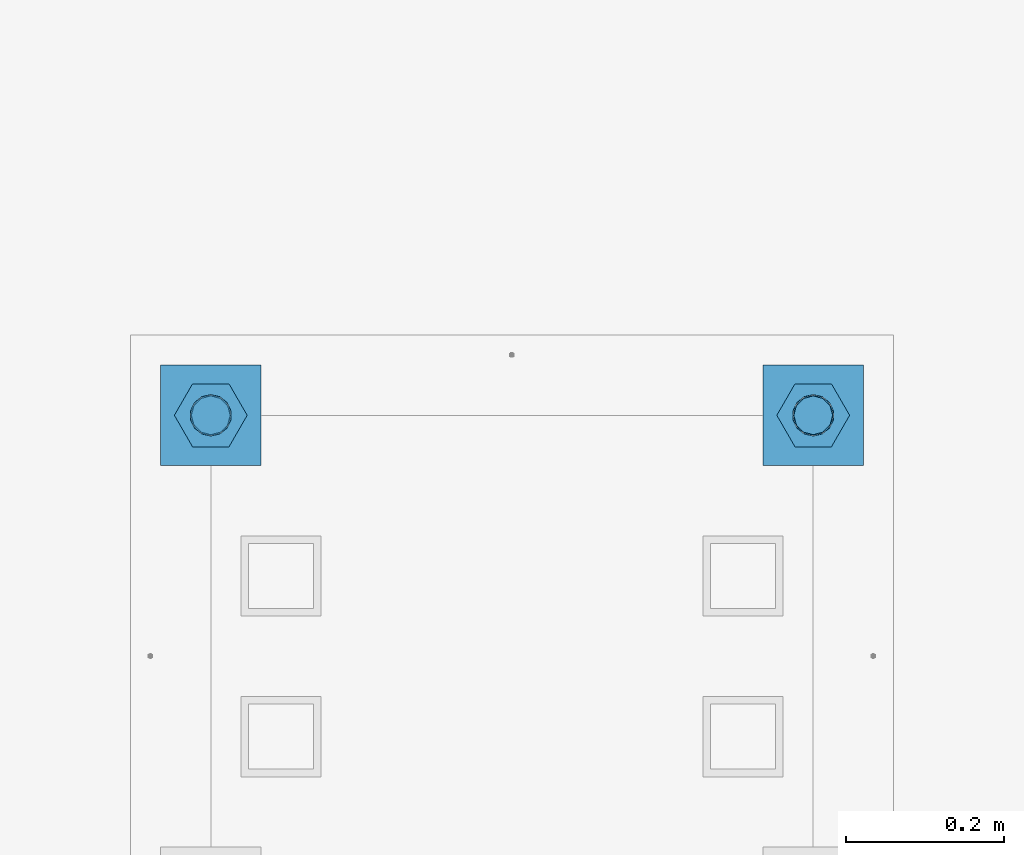
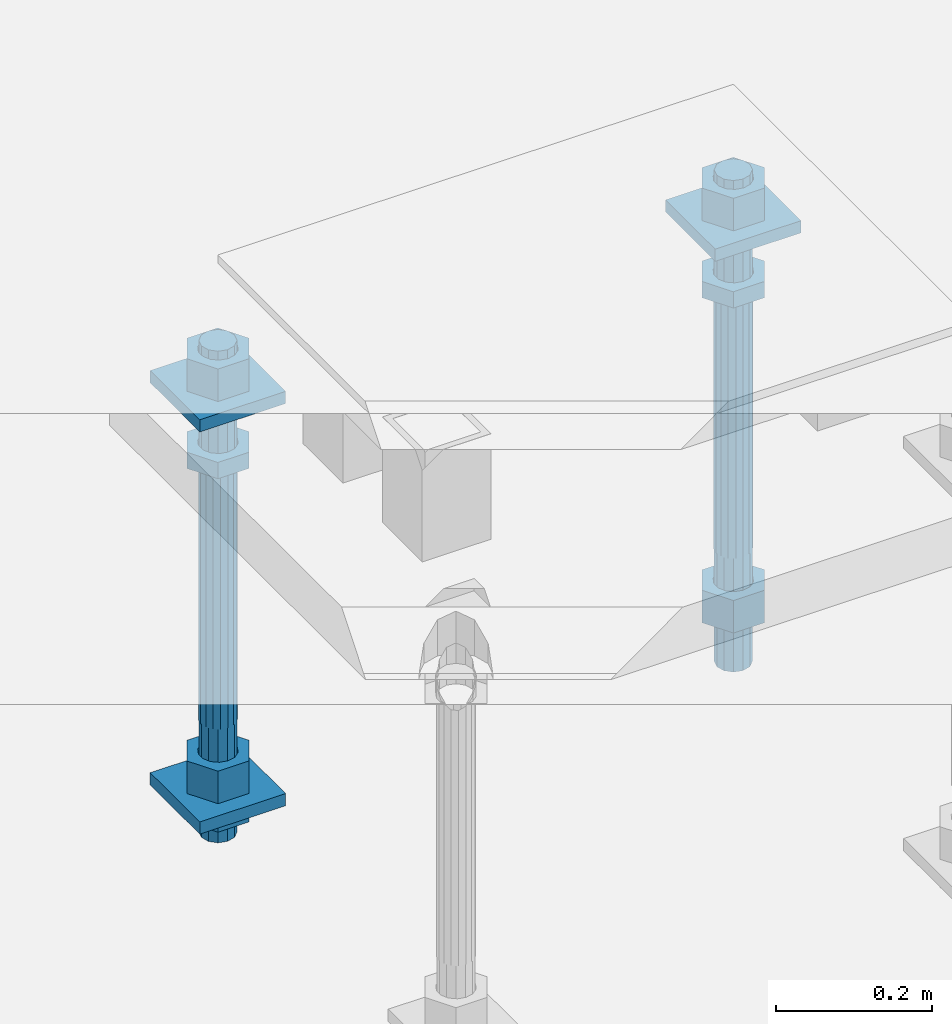
# One storey, part 2665 of 3843: 12 beams, 1 element without a shape of its own.
"""IFC2X3 building model written with IfcOpenShell, lengths in millimetres."""

import ifcopenshell
import ifcopenshell.guid

model = None  # the IFC model being written
_history = None  # IfcOwnerHistory: only IFC2X3 demands one
_inside = {}  # id of a spatial element -> (the spatial element, [elements in it])
_under = {}  # id of a project, library or spatial element -> (it, [spatial elements below it])
_declared = {}  # id of a project -> (the project, [libraries it declares])
_typed = {}  # id of a type object -> (the type object, [elements of that type])
_made_of = {}  # id of a material, layer set ... -> (it, [elements and type objects made of it])


def new_model(schema):
    """Start an empty IFC model of exactly this schema.

    Asked for "IFC4X3", IfcOpenShell would pick the latest addendum, in which some entities
    have other attributes; the version numbers below select the first issue.
    IFC2X3 requires an IfcOwnerHistory on every rooted entity: one is made here for all.
    """
    global model, _history
    if schema == "IFC4X3":
        model = ifcopenshell.file(schema_version=(4, 3, 0, 0))
    else:
        model = ifcopenshell.file(schema=schema)
    _inside.clear()
    _under.clear()
    _declared.clear()
    _typed.clear()
    _made_of.clear()
    _history = None
    if model.schema == "IFC2X3":
        org = make("IfcOrganization", Name="unknown")
        user = make(
            "IfcPersonAndOrganization",
            ThePerson=make("IfcPerson", FamilyName="unknown"),
            TheOrganization=org,
        )
        app = make(
            "IfcApplication",
            ApplicationDeveloper=org,
            Version="unknown",
            ApplicationFullName="unknown",
            ApplicationIdentifier="unknown",
        )
        _history = make(
            "IfcOwnerHistory",
            OwningUser=user,
            OwningApplication=app,
            ChangeAction="ADDED",
            CreationDate=0,
        )
    return model


def make(cls, **values):
    """One entity of the class cls with the attributes given. An attribute that is None is left unset."""
    return model.create_entity(
        cls, **{name: value for name, value in values.items() if value is not None}
    )


def rooted(cls, **values):
    """An entity with a GlobalId (a new one), such as an element, a storey or a relation."""
    return make(cls, GlobalId=ifcopenshell.guid.new(), OwnerHistory=_history, **values)


def si_unit(unit_type, name, prefix=None):
    """IfcSIUnit, for example si_unit("LENGTHUNIT", "METRE", prefix="MILLI")."""
    return make("IfcSIUnit", UnitType=unit_type, Prefix=prefix, Name=name)


def assignment(units):
    """IfcUnitAssignment: the units of a project."""
    return None if units is None else make("IfcUnitAssignment", Units=units)


def point(xyz):
    """IfcCartesianPoint."""
    return None if xyz is None else make("IfcCartesianPoint", Coordinates=xyz)


def direction(xyz):
    """IfcDirection."""
    return None if xyz is None else make("IfcDirection", DirectionRatios=xyz)


def frame(location, z_axis=None, x_axis=None):
    """IfcAxis2Placement3D, a coordinate frame: its origin and axes. An axis left out is left unset."""
    return make(
        "IfcAxis2Placement3D",
        Location=point(location),
        Axis=direction(z_axis),
        RefDirection=direction(x_axis),
    )


def origin_with_axes():
    """The frame at (0, 0, 0) with the z axis (0, 0, 1) and the x axis (1, 0, 0) written out."""
    return frame((0.0, 0.0, 0.0), z_axis=(0.0, 0.0, 1.0), x_axis=(1.0, 0.0, 0.0))


def place(relative_to, where):
    """IfcLocalPlacement: puts the frame where relative to a parent placement (None: the world)."""
    return make(
        "IfcLocalPlacement", PlacementRelTo=relative_to, RelativePlacement=where
    )


def context(
    kind, dimensions, precision=None, world=None, true_north=None, identifier=None
):
    """IfcGeometricRepresentationContext, for example the 3D "Model" context."""
    return make(
        "IfcGeometricRepresentationContext",
        ContextIdentifier=identifier,
        ContextType=kind,
        CoordinateSpaceDimension=dimensions,
        Precision=precision,
        WorldCoordinateSystem=world,
        TrueNorth=true_north,
    )


def subcontext(parent, identifier, kind, view, scale=None):
    """IfcGeometricRepresentationSubContext, for example "Body" below "Model"."""
    return make(
        "IfcGeometricRepresentationSubContext",
        ContextIdentifier=identifier,
        ContextType=kind,
        ParentContext=parent,
        TargetScale=scale,
        TargetView=view,
    )


def project(units=None, contexts=None):
    """IfcProject with its units and contexts."""
    return rooted(
        "IfcProject",
        Name="project",
        RepresentationContexts=contexts,
        UnitsInContext=assignment(units),
    )


def spatial(cls, under=None, at=None, **own):
    """A site, building, storey or space (cls), placed at a placement, below another one or the project."""
    s = rooted(cls, ObjectPlacement=at, **own)
    if under is not None:
        _under.setdefault(under.id(), (under, []))[1].append(s)
    return s


def faces_of(points, faces, orient=None, outer=None):
    """IfcFace entities. A face is a list of loops; a loop is a list of indices into points, from 0.

    orient and outer hold one flag for each loop. By default every Orientation is true, the
    first loop of a face is its IfcFaceOuterBound and the others are IfcFaceBound.
    """
    made = []
    for i, loops in enumerate(faces):
        bounds = []
        for j, loop in enumerate(loops):
            is_outer = j == 0 if outer is None else outer[i][j]
            bounds.append(
                make(
                    "IfcFaceOuterBound" if is_outer else "IfcFaceBound",
                    Bound=make("IfcPolyLoop", Polygon=[points[k] for k in loop]),
                    Orientation=True if orient is None else orient[i][j],
                )
            )
        made.append(make("IfcFace", Bounds=bounds))
    return made


def faceted_brep(points, faces, orient=None, outer=None, voids=None):
    """IfcFacetedBrep: a solid bounded by flat faces; with voids (closed shells), ...WithVoids."""
    shared = [point(p) for p in points]
    hull = make("IfcClosedShell", CfsFaces=faces_of(shared, faces, orient, outer))
    if voids is None:
        return make("IfcFacetedBrep", Outer=hull)
    return make(
        "IfcFacetedBrepWithVoids",
        Outer=hull,
        Voids=[
            make(cls, CfsFaces=faces_of(shared, fs, o, b)) for cls, fs, o, b in voids
        ],
    )


def shape(context_of_items, identifier, shape_type, items):
    """IfcShapeRepresentation: the items that make up one representation, for example the "Body"."""
    return make(
        "IfcShapeRepresentation",
        ContextOfItems=context_of_items,
        RepresentationIdentifier=identifier,
        RepresentationType=shape_type,
        Items=items,
    )


def material(Name=None, Category=None):
    """IfcMaterial."""
    return make("IfcMaterial", Name=Name, Category=Category)


def made_of(thing, what):
    """Note that an element or type object is made of a material, layer set ...; save() writes the relation."""
    if what is not None:
        _made_of.setdefault(what.id(), (what, []))[1].append(thing)
    return thing


def type_object(cls, material=None, **own):
    """A type object (cls), such as IfcWallType, which elements share."""
    return made_of(rooted(cls, **own), material)


def element(
    cls,
    number,
    at=None,
    inside=None,
    cuts=None,
    type_object=None,
    material=None,
    context=None,
    identifier="Body",
    shape_type=None,
    held_by="IfcProductDefinitionShape",
    body=None,
    shapes=None,
    **own,
):
    """One element of the class cls, such as IfcWall. Its Tag is "e" and its number.

    at: its placement. inside: the storey or other place that contains it. cuts: it is an
    opening in that element (IfcRelVoidsElement). A single representation is given by context,
    identifier, shape_type and body (its items); several are given by shapes. held_by: the class
    of the entity that holds the representations. save() writes the other relations.
    """
    e = rooted(cls, Tag="e%d" % number, ObjectPlacement=at, **own)
    if body is not None:
        shapes = [shape(context, identifier, shape_type, body)]
    if shapes is not None:
        e.Representation = make(held_by, Representations=shapes)
    if inside is not None:
        _inside.setdefault(inside.id(), (inside, []))[1].append(e)
    if cuts is not None:
        rooted(
            "IfcRelVoidsElement", RelatingBuildingElement=cuts, RelatedOpeningElement=e
        )
    if type_object is not None:
        _typed.setdefault(type_object.id(), (type_object, []))[1].append(e)
    return made_of(e, material)


def aggregate(whole, parts):
    """IfcRelAggregates: a whole, such as a stair, and the parts it consists of."""
    return rooted("IfcRelAggregates", RelatingObject=whole, RelatedObjects=parts)


def save(model, path):
    """Write the relations noted so far, then the file.

    IfcRelAggregates (storeys below a building ...), IfcRelContainedInSpatialStructure (elements
    in a storey), IfcRelDefinesByType, IfcRelAssociatesMaterial and IfcRelDeclares: one each for
    every whole, place, type object, material and project.
    """
    for whole, parts in _under.values():
        aggregate(whole, parts)
    for where, things in _inside.values():
        rooted(
            "IfcRelContainedInSpatialStructure",
            RelatedElements=things,
            RelatingStructure=where,
        )
    for kind, things in _typed.values():
        rooted("IfcRelDefinesByType", RelatedObjects=things, RelatingType=kind)
    for what, things in _made_of.values():
        rooted("IfcRelAssociatesMaterial", RelatedObjects=things, RelatingMaterial=what)
    for by, libraries in _declared.values():
        rooted("IfcRelDeclares", RelatingContext=by, RelatedDefinitions=libraries)
    model.write(path)


model = new_model("IFC2X3")

# Units and contexts
model_context = context("Model", 3, precision=1e-05, world=origin_with_axes())
body_context = subcontext(model_context, "Body", "Model", "MODEL_VIEW")
ifc_project = project(units=[si_unit("LENGTHUNIT", "METRE", prefix="MILLI"), si_unit("AREAUNIT", "SQUARE_METRE"), si_unit("VOLUMEUNIT", "CUBIC_METRE"), si_unit("MASSUNIT", "GRAM", prefix="KILO"), si_unit("TIMEUNIT", "SECOND"), si_unit("PLANEANGLEUNIT", "RADIAN"), si_unit("SOLIDANGLEUNIT", "STERADIAN"), si_unit("THERMODYNAMICTEMPERATUREUNIT", "DEGREE_CELSIUS"), si_unit("LUMINOUSINTENSITYUNIT", "LUMEN")], contexts=[model_context])

# Site, building, storey
site_placement = place(None, origin_with_axes())
site = spatial("IfcSite", under=ifc_project, at=site_placement, CompositionType="ELEMENT")
building_placement = place(site_placement, origin_with_axes())
building = spatial("IfcBuilding", under=site, at=building_placement, Name="Undefined", CompositionType="ELEMENT")
storey_placement = place(building_placement, origin_with_axes())
storey = spatial("IfcBuildingStorey", under=building, at=storey_placement, Name="Undefined", CompositionType="ELEMENT", Elevation=0.0)

# Assembly, beams
assembly_placement = place(storey_placement, origin_with_axes())
assembly = element("IfcElementAssembly", 1, at=assembly_placement, inside=storey, Name="TEMPLATE", AssemblyPlace="NOTDEFINED", PredefinedType="RIGID_FRAME")
ifc_material_1 = material(Name="STEEL/A572-50")
beam_type_1 = type_object("IfcBeamType", PredefinedType="NOTDEFINED")
beam_1_placement = place(assembly_placement, frame((118465.6, 18059.4000015259, 29873.575), z_axis=(1.0, 0.0, 0.0), x_axis=(0.0, 1.0, 0.0)))
beam_1 = element("IfcBeam", 2, at=beam_1_placement, type_object=beam_type_1, material=ifc_material_1, Name="WASHER_PLATE", context=body_context, shape_type="Brep", body=[
    faceted_brep([(0.0, 9.52500000000146, -63.5), (0.0, 9.52500000000146, 63.5), (127.0, 9.52500000000146, 63.5), (127.0, 9.52500000000146, -63.5), (0.0, -9.52500000000146, 63.5), (127.0, -9.52500000000146, 63.5), (0.0, -9.52500000000146, -63.5), (127.0, -9.52500000000146, -63.5)], [[[0, 1, 2, 3]], [[1, 4, 5, 2]], [[4, 6, 7, 5]], [[6, 0, 3, 7]], [[5, 7, 3, 2]], [[6, 4, 1, 0]]]),
])
beam_2_placement = place(assembly_placement, frame((119227.6, 18059.4000015259, 29873.575), z_axis=(1.0, 0.0, 0.0), x_axis=(0.0, 1.0, 0.0)))
beam_2 = element("IfcBeam", 3, at=beam_2_placement, type_object=beam_type_1, material=ifc_material_1, Name="WASHER_PLATE", context=body_context, shape_type="Brep", body=[
    faceted_brep([(0.0, 9.52500000000146, -63.5), (0.0, 9.52500000000146, 63.5), (127.0, 9.52500000000146, 63.5), (127.0, 9.52500000000146, -63.5), (0.0, -9.52500000000146, 63.5), (127.0, -9.52500000000146, 63.5), (0.0, -9.52500000000146, -63.5), (127.0, -9.52500000000146, -63.5)], [[[0, 1, 2, 3]], [[1, 4, 5, 2]], [[4, 6, 7, 5]], [[6, 0, 3, 7]], [[5, 7, 3, 2]], [[6, 4, 1, 0]]]),
])
beam_3_placement = place(assembly_placement, frame((118465.6, 18059.4000015259, 29244.925), z_axis=(1.0, 0.0, 0.0), x_axis=(0.0, 1.0, 0.0)))
beam_3 = element("IfcBeam", 4, at=beam_3_placement, type_object=beam_type_1, material=ifc_material_1, Name="WASHER_PLATE", context=body_context, shape_type="Brep", body=[
    faceted_brep([(0.0, 9.52500000000146, -63.5), (0.0, 9.52500000000146, 63.5), (127.0, 9.52500000000146, 63.5), (127.0, 9.52500000000146, -63.5), (0.0, -9.52500000000146, 63.5), (127.0, -9.52500000000146, 63.5), (0.0, -9.52500000000146, -63.5), (127.0, -9.52500000000146, -63.5)], [[[0, 1, 2, 3]], [[1, 4, 5, 2]], [[4, 6, 7, 5]], [[6, 0, 3, 7]], [[5, 7, 3, 2]], [[6, 4, 1, 0]]]),
])
ifc_material_2 = material(Name="STEEL/A36")
beam_type_2 = type_object("IfcBeamType", Name="2_HALF_NUT", PredefinedType="NOTDEFINED")
beam_4_placement = place(assembly_placement, frame((118465.6, 18122.9000015259, 29787.85), z_axis=(0.0, 1.0, 0.0), x_axis=(0.0, 0.0, -1.0)))
beam_4 = element("IfcBeam", 5, at=beam_4_placement, type_object=beam_type_2, material=ifc_material_2, Name="NUT", ObjectType="2_HALF_NUT", context=body_context, shape_type="Brep", body=[
    faceted_brep([(0.0, -46.0369987487793, 0.0), (0.0, -23.0184993743896, -39.869213104248), (25.4000000000015, -23.0184993743896, -39.869213104248), (25.4000000000015, -46.0369987487793, 0.0), (0.0, 23.0184993743896, -39.869213104248), (25.4000000000015, 23.0184993743896, -39.869213104248), (0.0, 46.0369987487793, 0.0), (25.4000000000015, 46.0369987487793, 0.0), (0.0, 23.0184993743896, 39.869213104248), (25.4000000000015, 23.0184993743896, 39.869213104248), (0.0, -23.0184993743896, 39.869213104248), (25.4000000000015, -23.0184993743896, 39.869213104248), (0.0, 0.0, 26.1940002441406), (0.0, 11.3650617044477, 23.5999013092805), (25.4000000000015, 11.3650617044477, 23.5999013092805), (25.4000000000015, 0.0, 26.1940002441406), (0.0, 20.4791109456419, 16.3316083006721), (25.4000000000015, 20.4791109456419, 16.3316083006721), (0.0, 25.5370200498292, 5.82867859874386), (25.4000000000015, 25.5370200498292, 5.82867859874386), (0.0, 25.5370200498292, -5.82867859874386), (25.4000000000015, 25.5370200498292, -5.82867859874386), (0.0, 20.4791109456419, -16.3316083006721), (25.4000000000015, 20.4791109456419, -16.3316083006721), (0.0, 11.3650617044477, -23.5999013092805), (25.4000000000015, 11.3650617044477, -23.5999013092805), (0.0, 0.0, -26.1940002441406), (25.4000000000015, 0.0, -26.1940002441406), (0.0, -11.3650617044477, -23.5999013092805), (25.4000000000015, -11.3650617044477, -23.5999013092805), (0.0, -20.4791109456419, -16.3316083006721), (25.4000000000015, -20.4791109456419, -16.3316083006721), (0.0, -25.5370200498292, -5.82867859874386), (25.4000000000015, -25.5370200498292, -5.82867859874386), (0.0, -25.5370200498292, 5.82867859874386), (25.4000000000015, -25.5370200498292, 5.82867859874386), (0.0, -20.4791109456419, 16.3316083006721), (25.4000000000015, -20.4791109456419, 16.3316083006721), (0.0, -11.3650617044477, 23.5999013092805), (25.4000000000015, -11.3650617044477, 23.5999013092805)], [[[0, 1, 2, 3]], [[1, 4, 5, 2]], [[4, 6, 7, 5]], [[6, 8, 9, 7]], [[8, 10, 11, 9]], [[10, 0, 3, 11]], [[12, 13, 14, 15]], [[13, 16, 17, 14]], [[16, 18, 19, 17]], [[18, 20, 21, 19]], [[20, 22, 23, 21]], [[22, 24, 25, 23]], [[24, 26, 27, 25]], [[26, 28, 29, 27]], [[28, 30, 31, 29]], [[30, 32, 33, 31]], [[32, 34, 35, 33]], [[34, 36, 37, 35]], [[36, 38, 39, 37]], [[38, 12, 15, 39]], [[5, 7, 9, 11, 3, 2], [17, 19, 21, 23, 25, 27, 29, 31, 33, 35, 37, 39, 15, 14]], [[10, 8, 6, 4, 1, 0], [38, 36, 34, 32, 30, 28, 26, 24, 22, 20, 18, 16, 13, 12]]]),
])
beam_5_placement = place(assembly_placement, frame((118465.6, 18122.9000015259, 29235.4), z_axis=(0.0, 1.0, 0.0), x_axis=(0.0, 0.0, -1.0)))
beam_5 = element("IfcBeam", 6, at=beam_5_placement, type_object=beam_type_2, material=ifc_material_2, Name="NUT", ObjectType="2_HALF_NUT", context=body_context, shape_type="Brep", body=[
    faceted_brep([(0.0, -46.0369987487793, 0.0), (0.0, -23.0184993743896, -39.869213104248), (25.4000000000015, -23.0184993743896, -39.869213104248), (25.4000000000015, -46.0369987487793, 0.0), (0.0, 23.0184993743896, -39.869213104248), (25.4000000000015, 23.0184993743896, -39.869213104248), (0.0, 46.0369987487793, 0.0), (25.4000000000015, 46.0369987487793, 0.0), (0.0, 23.0184993743896, 39.869213104248), (25.4000000000015, 23.0184993743896, 39.869213104248), (0.0, -23.0184993743896, 39.869213104248), (25.4000000000015, -23.0184993743896, 39.869213104248), (0.0, 0.0, 26.1940002441406), (0.0, 11.3650617044477, 23.5999013092805), (25.4000000000015, 11.3650617044477, 23.5999013092805), (25.4000000000015, 0.0, 26.1940002441406), (0.0, 20.4791109456419, 16.3316083006721), (25.4000000000015, 20.4791109456419, 16.3316083006721), (0.0, 25.5370200498292, 5.82867859874386), (25.4000000000015, 25.5370200498292, 5.82867859874386), (0.0, 25.5370200498292, -5.82867859874386), (25.4000000000015, 25.5370200498292, -5.82867859874386), (0.0, 20.4791109456419, -16.3316083006721), (25.4000000000015, 20.4791109456419, -16.3316083006721), (0.0, 11.3650617044477, -23.5999013092805), (25.4000000000015, 11.3650617044477, -23.5999013092805), (0.0, 0.0, -26.1940002441406), (25.4000000000015, 0.0, -26.1940002441406), (0.0, -11.3650617044477, -23.5999013092805), (25.4000000000015, -11.3650617044477, -23.5999013092805), (0.0, -20.4791109456419, -16.3316083006721), (25.4000000000015, -20.4791109456419, -16.3316083006721), (0.0, -25.5370200498292, -5.82867859874386), (25.4000000000015, -25.5370200498292, -5.82867859874386), (0.0, -25.5370200498292, 5.82867859874386), (25.4000000000015, -25.5370200498292, 5.82867859874386), (0.0, -20.4791109456419, 16.3316083006721), (25.4000000000015, -20.4791109456419, 16.3316083006721), (0.0, -11.3650617044477, 23.5999013092805), (25.4000000000015, -11.3650617044477, 23.5999013092805)], [[[0, 1, 2, 3]], [[1, 4, 5, 2]], [[4, 6, 7, 5]], [[6, 8, 9, 7]], [[8, 10, 11, 9]], [[10, 0, 3, 11]], [[12, 13, 14, 15]], [[13, 16, 17, 14]], [[16, 18, 19, 17]], [[18, 20, 21, 19]], [[20, 22, 23, 21]], [[22, 24, 25, 23]], [[24, 26, 27, 25]], [[26, 28, 29, 27]], [[28, 30, 31, 29]], [[30, 32, 33, 31]], [[32, 34, 35, 33]], [[34, 36, 37, 35]], [[36, 38, 39, 37]], [[38, 12, 15, 39]], [[5, 7, 9, 11, 3, 2], [17, 19, 21, 23, 25, 27, 29, 31, 33, 35, 37, 39, 15, 14]], [[10, 8, 6, 4, 1, 0], [38, 36, 34, 32, 30, 28, 26, 24, 22, 20, 18, 16, 13, 12]]]),
])
beam_6_placement = place(assembly_placement, frame((119227.6, 18122.9000015259, 29787.85), z_axis=(0.0, 1.0, 0.0), x_axis=(0.0, 0.0, -1.0)))
beam_6 = element("IfcBeam", 7, at=beam_6_placement, type_object=beam_type_2, material=ifc_material_2, Name="NUT", ObjectType="2_HALF_NUT", context=body_context, shape_type="Brep", body=[
    faceted_brep([(0.0, -46.0369987487793, 0.0), (0.0, -23.0184993743896, -39.869213104248), (25.4000000000015, -23.0184993743896, -39.869213104248), (25.4000000000015, -46.0369987487793, 0.0), (0.0, 23.0184993743896, -39.869213104248), (25.4000000000015, 23.0184993743896, -39.869213104248), (0.0, 46.0369987487793, 0.0), (25.4000000000015, 46.0369987487793, 0.0), (0.0, 23.0184993743896, 39.869213104248), (25.4000000000015, 23.0184993743896, 39.869213104248), (0.0, -23.0184993743896, 39.869213104248), (25.4000000000015, -23.0184993743896, 39.869213104248), (0.0, 0.0, 26.1940002441406), (0.0, 11.3650617044477, 23.5999013092805), (25.4000000000015, 11.3650617044477, 23.5999013092805), (25.4000000000015, 0.0, 26.1940002441406), (0.0, 20.4791109456419, 16.3316083006721), (25.4000000000015, 20.4791109456419, 16.3316083006721), (0.0, 25.5370200498292, 5.82867859874386), (25.4000000000015, 25.5370200498292, 5.82867859874386), (0.0, 25.5370200498292, -5.82867859874386), (25.4000000000015, 25.5370200498292, -5.82867859874386), (0.0, 20.4791109456419, -16.3316083006721), (25.4000000000015, 20.4791109456419, -16.3316083006721), (0.0, 11.3650617044477, -23.5999013092805), (25.4000000000015, 11.3650617044477, -23.5999013092805), (0.0, 0.0, -26.1940002441406), (25.4000000000015, 0.0, -26.1940002441406), (0.0, -11.3650617044477, -23.5999013092805), (25.4000000000015, -11.3650617044477, -23.5999013092805), (0.0, -20.4791109456419, -16.3316083006721), (25.4000000000015, -20.4791109456419, -16.3316083006721), (0.0, -25.5370200498292, -5.82867859874386), (25.4000000000015, -25.5370200498292, -5.82867859874386), (0.0, -25.5370200498292, 5.82867859874386), (25.4000000000015, -25.5370200498292, 5.82867859874386), (0.0, -20.4791109456419, 16.3316083006721), (25.4000000000015, -20.4791109456419, 16.3316083006721), (0.0, -11.3650617044477, 23.5999013092805), (25.4000000000015, -11.3650617044477, 23.5999013092805)], [[[0, 1, 2, 3]], [[1, 4, 5, 2]], [[4, 6, 7, 5]], [[6, 8, 9, 7]], [[8, 10, 11, 9]], [[10, 0, 3, 11]], [[12, 13, 14, 15]], [[13, 16, 17, 14]], [[16, 18, 19, 17]], [[18, 20, 21, 19]], [[20, 22, 23, 21]], [[22, 24, 25, 23]], [[24, 26, 27, 25]], [[26, 28, 29, 27]], [[28, 30, 31, 29]], [[30, 32, 33, 31]], [[32, 34, 35, 33]], [[34, 36, 37, 35]], [[36, 38, 39, 37]], [[38, 12, 15, 39]], [[5, 7, 9, 11, 3, 2], [17, 19, 21, 23, 25, 27, 29, 31, 33, 35, 37, 39, 15, 14]], [[10, 8, 6, 4, 1, 0], [38, 36, 34, 32, 30, 28, 26, 24, 22, 20, 18, 16, 13, 12]]]),
])
beam_type_3 = type_object("IfcBeamType", Name="2_HEAVY_HEX_NUT", PredefinedType="NOTDEFINED")
beam_7_placement = place(assembly_placement, frame((118465.6, 18122.9000015259, 29933.9), z_axis=(0.0, 1.0, 0.0), x_axis=(0.0, 0.0, -1.0)))
beam_7 = element("IfcBeam", 8, at=beam_7_placement, type_object=beam_type_3, material=ifc_material_2, Name="NUT", ObjectType="2_HEAVY_HEX_NUT", context=body_context, shape_type="Brep", body=[
    faceted_brep([(0.0, -46.0369987487793, 0.0), (0.0, -23.0184993743896, -39.869213104248), (50.7999999999993, -23.0184993743896, -39.869213104248), (50.7999999999993, -46.0369987487793, 0.0), (0.0, 23.0184993743896, -39.869213104248), (50.7999999999993, 23.0184993743896, -39.869213104248), (0.0, 46.0369987487793, 0.0), (50.7999999999993, 46.0369987487793, 0.0), (0.0, 23.0184993743896, 39.869213104248), (50.7999999999993, 23.0184993743896, 39.869213104248), (0.0, -23.0184993743896, 39.869213104248), (50.7999999999993, -23.0184993743896, 39.869213104248), (0.0, 0.0, 26.1940002441406), (0.0, 11.3650617044477, 23.5999013092805), (50.7999999999993, 11.3650617044477, 23.5999013092805), (50.7999999999993, 0.0, 26.1940002441406), (0.0, 20.4791109456419, 16.3316083006721), (50.7999999999993, 20.4791109456419, 16.3316083006721), (0.0, 25.5370200498292, 5.82867859874386), (50.7999999999993, 25.5370200498292, 5.82867859874386), (0.0, 25.5370200498292, -5.82867859874386), (50.7999999999993, 25.5370200498292, -5.82867859874386), (0.0, 20.4791109456419, -16.3316083006721), (50.7999999999993, 20.4791109456419, -16.3316083006721), (0.0, 11.3650617044477, -23.5999013092805), (50.7999999999993, 11.3650617044477, -23.5999013092805), (0.0, 0.0, -26.1940002441406), (50.7999999999993, 0.0, -26.1940002441406), (0.0, -11.3650617044477, -23.5999013092805), (50.7999999999993, -11.3650617044477, -23.5999013092805), (0.0, -20.4791109456419, -16.3316083006721), (50.7999999999993, -20.4791109456419, -16.3316083006721), (0.0, -25.5370200498292, -5.82867859874386), (50.7999999999993, -25.5370200498292, -5.82867859874386), (0.0, -25.5370200498292, 5.82867859874386), (50.7999999999993, -25.5370200498292, 5.82867859874386), (0.0, -20.4791109456419, 16.3316083006721), (50.7999999999993, -20.4791109456419, 16.3316083006721), (0.0, -11.3650617044477, 23.5999013092805), (50.7999999999993, -11.3650617044477, 23.5999013092805)], [[[0, 1, 2, 3]], [[1, 4, 5, 2]], [[4, 6, 7, 5]], [[6, 8, 9, 7]], [[8, 10, 11, 9]], [[10, 0, 3, 11]], [[12, 13, 14, 15]], [[13, 16, 17, 14]], [[16, 18, 19, 17]], [[18, 20, 21, 19]], [[20, 22, 23, 21]], [[22, 24, 25, 23]], [[24, 26, 27, 25]], [[26, 28, 29, 27]], [[28, 30, 31, 29]], [[30, 32, 33, 31]], [[32, 34, 35, 33]], [[34, 36, 37, 35]], [[36, 38, 39, 37]], [[38, 12, 15, 39]], [[5, 7, 9, 11, 3, 2], [17, 19, 21, 23, 25, 27, 29, 31, 33, 35, 37, 39, 15, 14]], [[10, 8, 6, 4, 1, 0], [38, 36, 34, 32, 30, 28, 26, 24, 22, 20, 18, 16, 13, 12]]]),
])
beam_8_placement = place(assembly_placement, frame((118465.6, 18122.9000015259, 29305.25), z_axis=(0.0, 1.0, 0.0), x_axis=(0.0, 0.0, -1.0)))
beam_8 = element("IfcBeam", 9, at=beam_8_placement, type_object=beam_type_3, material=ifc_material_2, Name="NUT", ObjectType="2_HEAVY_HEX_NUT", context=body_context, shape_type="Brep", body=[
    faceted_brep([(0.0, -46.0369987487793, 0.0), (0.0, -23.0184993743896, -39.869213104248), (50.7999999999993, -23.0184993743896, -39.869213104248), (50.7999999999993, -46.0369987487793, 0.0), (0.0, 23.0184993743896, -39.869213104248), (50.7999999999993, 23.0184993743896, -39.869213104248), (0.0, 46.0369987487793, 0.0), (50.7999999999993, 46.0369987487793, 0.0), (0.0, 23.0184993743896, 39.869213104248), (50.7999999999993, 23.0184993743896, 39.869213104248), (0.0, -23.0184993743896, 39.869213104248), (50.7999999999993, -23.0184993743896, 39.869213104248), (0.0, 0.0, 26.1940002441406), (0.0, 11.3650617044477, 23.5999013092805), (50.7999999999993, 11.3650617044477, 23.5999013092805), (50.7999999999993, 0.0, 26.1940002441406), (0.0, 20.4791109456419, 16.3316083006721), (50.7999999999993, 20.4791109456419, 16.3316083006721), (0.0, 25.5370200498292, 5.82867859874386), (50.7999999999993, 25.5370200498292, 5.82867859874386), (0.0, 25.5370200498292, -5.82867859874386), (50.7999999999993, 25.5370200498292, -5.82867859874386), (0.0, 20.4791109456419, -16.3316083006721), (50.7999999999993, 20.4791109456419, -16.3316083006721), (0.0, 11.3650617044477, -23.5999013092805), (50.7999999999993, 11.3650617044477, -23.5999013092805), (0.0, 0.0, -26.1940002441406), (50.7999999999993, 0.0, -26.1940002441406), (0.0, -11.3650617044477, -23.5999013092805), (50.7999999999993, -11.3650617044477, -23.5999013092805), (0.0, -20.4791109456419, -16.3316083006721), (50.7999999999993, -20.4791109456419, -16.3316083006721), (0.0, -25.5370200498292, -5.82867859874386), (50.7999999999993, -25.5370200498292, -5.82867859874386), (0.0, -25.5370200498292, 5.82867859874386), (50.7999999999993, -25.5370200498292, 5.82867859874386), (0.0, -20.4791109456419, 16.3316083006721), (50.7999999999993, -20.4791109456419, 16.3316083006721), (0.0, -11.3650617044477, 23.5999013092805), (50.7999999999993, -11.3650617044477, 23.5999013092805)], [[[0, 1, 2, 3]], [[1, 4, 5, 2]], [[4, 6, 7, 5]], [[6, 8, 9, 7]], [[8, 10, 11, 9]], [[10, 0, 3, 11]], [[12, 13, 14, 15]], [[13, 16, 17, 14]], [[16, 18, 19, 17]], [[18, 20, 21, 19]], [[20, 22, 23, 21]], [[22, 24, 25, 23]], [[24, 26, 27, 25]], [[26, 28, 29, 27]], [[28, 30, 31, 29]], [[30, 32, 33, 31]], [[32, 34, 35, 33]], [[34, 36, 37, 35]], [[36, 38, 39, 37]], [[38, 12, 15, 39]], [[5, 7, 9, 11, 3, 2], [17, 19, 21, 23, 25, 27, 29, 31, 33, 35, 37, 39, 15, 14]], [[10, 8, 6, 4, 1, 0], [38, 36, 34, 32, 30, 28, 26, 24, 22, 20, 18, 16, 13, 12]]]),
])
beam_9_placement = place(assembly_placement, frame((119227.6, 18122.9000015259, 29933.9), z_axis=(0.0, 1.0, 0.0), x_axis=(0.0, 0.0, -1.0)))
beam_9 = element("IfcBeam", 10, at=beam_9_placement, type_object=beam_type_3, material=ifc_material_2, Name="NUT", ObjectType="2_HEAVY_HEX_NUT", context=body_context, shape_type="Brep", body=[
    faceted_brep([(0.0, -46.0369987487793, 0.0), (0.0, -23.0184993743896, -39.869213104248), (50.7999999999993, -23.0184993743896, -39.869213104248), (50.7999999999993, -46.0369987487793, 0.0), (0.0, 23.0184993743896, -39.869213104248), (50.7999999999993, 23.0184993743896, -39.869213104248), (0.0, 46.0369987487793, 0.0), (50.7999999999993, 46.0369987487793, 0.0), (0.0, 23.0184993743896, 39.869213104248), (50.7999999999993, 23.0184993743896, 39.869213104248), (0.0, -23.0184993743896, 39.869213104248), (50.7999999999993, -23.0184993743896, 39.869213104248), (0.0, 0.0, 26.1940002441406), (0.0, 11.3650617044477, 23.5999013092805), (50.7999999999993, 11.3650617044477, 23.5999013092805), (50.7999999999993, 0.0, 26.1940002441406), (0.0, 20.4791109456419, 16.3316083006721), (50.7999999999993, 20.4791109456419, 16.3316083006721), (0.0, 25.5370200498292, 5.82867859874386), (50.7999999999993, 25.5370200498292, 5.82867859874386), (0.0, 25.5370200498292, -5.82867859874386), (50.7999999999993, 25.5370200498292, -5.82867859874386), (0.0, 20.4791109456419, -16.3316083006721), (50.7999999999993, 20.4791109456419, -16.3316083006721), (0.0, 11.3650617044477, -23.5999013092805), (50.7999999999993, 11.3650617044477, -23.5999013092805), (0.0, 0.0, -26.1940002441406), (50.7999999999993, 0.0, -26.1940002441406), (0.0, -11.3650617044477, -23.5999013092805), (50.7999999999993, -11.3650617044477, -23.5999013092805), (0.0, -20.4791109456419, -16.3316083006721), (50.7999999999993, -20.4791109456419, -16.3316083006721), (0.0, -25.5370200498292, -5.82867859874386), (50.7999999999993, -25.5370200498292, -5.82867859874386), (0.0, -25.5370200498292, 5.82867859874386), (50.7999999999993, -25.5370200498292, 5.82867859874386), (0.0, -20.4791109456419, 16.3316083006721), (50.7999999999993, -20.4791109456419, 16.3316083006721), (0.0, -11.3650617044477, 23.5999013092805), (50.7999999999993, -11.3650617044477, 23.5999013092805)], [[[0, 1, 2, 3]], [[1, 4, 5, 2]], [[4, 6, 7, 5]], [[6, 8, 9, 7]], [[8, 10, 11, 9]], [[10, 0, 3, 11]], [[12, 13, 14, 15]], [[13, 16, 17, 14]], [[16, 18, 19, 17]], [[18, 20, 21, 19]], [[20, 22, 23, 21]], [[22, 24, 25, 23]], [[24, 26, 27, 25]], [[26, 28, 29, 27]], [[28, 30, 31, 29]], [[30, 32, 33, 31]], [[32, 34, 35, 33]], [[34, 36, 37, 35]], [[36, 38, 39, 37]], [[38, 12, 15, 39]], [[5, 7, 9, 11, 3, 2], [17, 19, 21, 23, 25, 27, 29, 31, 33, 35, 37, 39, 15, 14]], [[10, 8, 6, 4, 1, 0], [38, 36, 34, 32, 30, 28, 26, 24, 22, 20, 18, 16, 13, 12]]]),
])
beam_10_placement = place(assembly_placement, frame((119227.6, 18122.9000015259, 29305.25), z_axis=(0.0, 1.0, 0.0), x_axis=(0.0, 0.0, -1.0)))
beam_10 = element("IfcBeam", 11, at=beam_10_placement, type_object=beam_type_3, material=ifc_material_2, Name="NUT", ObjectType="2_HEAVY_HEX_NUT", context=body_context, shape_type="Brep", body=[
    faceted_brep([(0.0, -46.0369987487793, 0.0), (0.0, -23.0184993743896, -39.869213104248), (50.7999999999993, -23.0184993743896, -39.869213104248), (50.7999999999993, -46.0369987487793, 0.0), (0.0, 23.0184993743896, -39.869213104248), (50.7999999999993, 23.0184993743896, -39.869213104248), (0.0, 46.0369987487793, 0.0), (50.7999999999993, 46.0369987487793, 0.0), (0.0, 23.0184993743896, 39.869213104248), (50.7999999999993, 23.0184993743896, 39.869213104248), (0.0, -23.0184993743896, 39.869213104248), (50.7999999999993, -23.0184993743896, 39.869213104248), (0.0, 0.0, 26.1940002441406), (0.0, 11.3650617044477, 23.5999013092805), (50.7999999999993, 11.3650617044477, 23.5999013092805), (50.7999999999993, 0.0, 26.1940002441406), (0.0, 20.4791109456419, 16.3316083006721), (50.7999999999993, 20.4791109456419, 16.3316083006721), (0.0, 25.5370200498292, 5.82867859874386), (50.7999999999993, 25.5370200498292, 5.82867859874386), (0.0, 25.5370200498292, -5.82867859874386), (50.7999999999993, 25.5370200498292, -5.82867859874386), (0.0, 20.4791109456419, -16.3316083006721), (50.7999999999993, 20.4791109456419, -16.3316083006721), (0.0, 11.3650617044477, -23.5999013092805), (50.7999999999993, 11.3650617044477, -23.5999013092805), (0.0, 0.0, -26.1940002441406), (50.7999999999993, 0.0, -26.1940002441406), (0.0, -11.3650617044477, -23.5999013092805), (50.7999999999993, -11.3650617044477, -23.5999013092805), (0.0, -20.4791109456419, -16.3316083006721), (50.7999999999993, -20.4791109456419, -16.3316083006721), (0.0, -25.5370200498292, -5.82867859874386), (50.7999999999993, -25.5370200498292, -5.82867859874386), (0.0, -25.5370200498292, 5.82867859874386), (50.7999999999993, -25.5370200498292, 5.82867859874386), (0.0, -20.4791109456419, 16.3316083006721), (50.7999999999993, -20.4791109456419, 16.3316083006721), (0.0, -11.3650617044477, 23.5999013092805), (50.7999999999993, -11.3650617044477, 23.5999013092805)], [[[0, 1, 2, 3]], [[1, 4, 5, 2]], [[4, 6, 7, 5]], [[6, 8, 9, 7]], [[8, 10, 11, 9]], [[10, 0, 3, 11]], [[12, 13, 14, 15]], [[13, 16, 17, 14]], [[16, 18, 19, 17]], [[18, 20, 21, 19]], [[20, 22, 23, 21]], [[22, 24, 25, 23]], [[24, 26, 27, 25]], [[26, 28, 29, 27]], [[28, 30, 31, 29]], [[30, 32, 33, 31]], [[32, 34, 35, 33]], [[34, 36, 37, 35]], [[36, 38, 39, 37]], [[38, 12, 15, 39]], [[5, 7, 9, 11, 3, 2], [17, 19, 21, 23, 25, 27, 29, 31, 33, 35, 37, 39, 15, 14]], [[10, 8, 6, 4, 1, 0], [38, 36, 34, 32, 30, 28, 26, 24, 22, 20, 18, 16, 13, 12]]]),
])
ifc_material_3 = material()
beam_type_4 = type_object("IfcBeamType", PredefinedType="NOTDEFINED")
beam_11_placement = place(assembly_placement, frame((118465.600001526, 18122.9, 29762.45), z_axis=(1.0, 0.0, 0.0), x_axis=(0.0, 0.0, -1.0)))
beam_11 = element("IfcBeam", 12, at=beam_11_placement, type_object=beam_type_4, material=ifc_material_3, Name="ANCHOR_ROD", context=body_context, shape_type="Brep", body=[
    faceted_brep([(0.0, -23.4665401257807, -9.72015918207035), (0.0, -17.9605122421344, -17.9605122421417), (406.399999999998, -17.9605122421344, -17.9605122421417), (406.399999999998, -23.4665401257807, -9.72015918207035), (0.0, -9.72015918207762, -23.466540125788), (406.399999999998, -9.72015918207762, -23.466540125788), (0.0, 0.0, -25.4000000000015), (406.399999999998, 0.0, -25.4000000000015), (0.0, 9.72015918207762, -23.466540125788), (406.399999999998, 9.72015918207762, -23.466540125788), (0.0, 17.9605122421344, -17.9605122421417), (406.399999999998, 17.9605122421344, -17.9605122421417), (0.0, 23.4665401257807, -9.72015918207035), (406.399999999998, 23.4665401257807, -9.72015918207035), (0.0, 25.3999996185303, 0.0), (406.399999999998, 25.3999999999942, 0.0), (0.0, 23.4665401257807, 9.72015918207035), (406.399999999998, 23.4665401257807, 9.72015918207035), (0.0, 17.9605122421344, 17.9605122421417), (406.399999999998, 17.9605122421344, 17.9605122421417), (0.0, 9.72015918207762, 23.466540125788), (406.399999999998, 9.72015918207762, 23.466540125788), (0.0, 0.0, 25.4000000000015), (406.399999999998, 0.0, 25.4000000000015), (0.0, -9.72015918207762, 23.466540125788), (406.399999999998, -9.72015918207762, 23.466540125788), (0.0, -17.9605122421344, 17.9605122421417), (406.399999999998, -17.9605122421344, 17.9605122421417), (0.0, -23.4665401257807, 9.72015918207035), (406.399999999998, -23.4665401257807, 9.72015918207035), (0.0, -25.3999996185303, 0.0), (406.399999999998, -25.3999999999942, 0.0), (584.200000000001, -12.2499999999854, -21.2176223927163), (584.200000000001, 1.45519152283669e-11, -24.5), (584.200000000001, 12.2500000000146, -21.2176223927163), (584.200000000001, 21.2176223927381, -12.25), (584.200000000001, 24.5000000000146, 0.0), (584.200000000001, 21.2176223927381, 12.25), (584.200000000001, 12.2500000000146, 21.2176223927163), (584.200000000001, 1.45519152283669e-11, 24.5), (584.200000000001, -12.2499999999854, 21.2176223927163), (584.200000000001, -21.217622392709, 12.25), (584.200000000001, -24.4999999999854, 0.0), (584.200000000001, -21.217622392709, -12.25), (406.399999999998, -24.4999999999854, 0.0), (406.399999999998, -21.217622392709, -12.25), (406.399999999998, -12.2499999999854, -21.2176223927163), (406.399999999998, 1.45519152283669e-11, -24.5), (406.399999999998, 12.2500000000146, -21.2176223927163), (406.399999999998, 21.2176223927381, -12.25), (406.399999999998, 24.5000000000146, 0.0), (406.399999999998, 21.2176223927381, 12.25), (406.399999999998, 12.2500000000146, 21.2176223927163), (406.399999999998, 1.45519152283669e-11, 24.5), (406.399999999998, -12.2499999999854, 21.2176223927163), (406.399999999998, -21.217622392709, 12.25), (0.0, 12.2500000000146, 21.2176223927163), (0.0, 1.45519152283669e-11, 24.5), (0.0, -12.2499999999854, 21.2176223927163), (0.0, -21.217622392709, 12.25), (0.0, -24.4999999999854, 0.0), (0.0, -21.217622392709, -12.25), (0.0, -12.2499999999854, -21.2176223927163), (0.0, 1.45519152283669e-11, -24.5), (0.0, 12.2500000000146, -21.2176223927163), (0.0, 21.2176223927381, -12.25), (0.0, 24.5000000000146, 0.0), (0.0, 21.2176223927381, 12.25), (-184.150000000001, -21.217622392709, 12.25), (-184.150000000001, -12.2499999999854, 21.2176223927163), (-184.150000000001, 1.45519152283669e-11, 24.5), (-184.150000000001, 12.2500000000146, 21.2176223927163), (-184.150000000001, 21.2176223927381, 12.25), (-184.150000000001, 24.5000000000146, 0.0), (-184.150000000001, 21.2176223927381, -12.25), (-184.150000000001, 12.2500000000146, -21.2176223927163), (-184.150000000001, 1.45519152283669e-11, -24.5), (-184.150000000001, -12.2499999999854, -21.2176223927163), (-184.150000000001, -21.217622392709, -12.25), (-184.150000000001, -24.4999999999854, 0.0)], [[[0, 1, 2, 3]], [[1, 4, 5, 2]], [[4, 6, 7, 5]], [[6, 8, 9, 7]], [[8, 10, 11, 9]], [[10, 12, 13, 11]], [[12, 14, 15, 13]], [[14, 16, 17, 15]], [[16, 18, 19, 17]], [[18, 20, 21, 19]], [[20, 22, 23, 21]], [[22, 24, 25, 23]], [[24, 26, 27, 25]], [[26, 28, 29, 27]], [[28, 30, 31, 29]], [[32, 33, 34, 35, 36, 37, 38, 39, 40, 41, 42, 43]], [[43, 42, 44, 45]], [[32, 43, 45, 46]], [[33, 32, 46, 47]], [[34, 33, 47, 48]], [[35, 34, 48, 49]], [[36, 35, 49, 50]], [[37, 36, 50, 51]], [[38, 37, 51, 52]], [[39, 38, 52, 53]], [[40, 39, 53, 54]], [[41, 40, 54, 55]], [[42, 41, 55, 44]], [[2, 5, 7, 9, 11, 13, 15, 17, 19, 21, 23, 25, 27, 29, 31, 3], [54, 53, 52, 51, 50, 49, 48, 47, 46, 45, 44, 55]], [[30, 0, 3, 31]], [[28, 26, 24, 22, 20, 18, 16, 14, 12, 10, 8, 6, 4, 1, 0, 30], [56, 57, 58, 59, 60, 61, 62, 63, 64, 65, 66, 67]], [[68, 69, 70, 71, 72, 73, 74, 75, 76, 77, 78, 79]], [[71, 70, 57, 56]], [[72, 71, 56, 67]], [[73, 72, 67, 66]], [[74, 73, 66, 65]], [[75, 74, 65, 64]], [[76, 75, 64, 63]], [[77, 76, 63, 62]], [[78, 77, 62, 61]], [[79, 78, 61, 60]], [[68, 79, 60, 59]], [[69, 68, 59, 58]], [[70, 69, 58, 57]]]),
])
beam_12_placement = place(assembly_placement, frame((119227.600001526, 18122.9, 29762.45), z_axis=(1.0, 0.0, 0.0), x_axis=(0.0, 0.0, -1.0)))
beam_12 = element("IfcBeam", 13, at=beam_12_placement, type_object=beam_type_4, material=ifc_material_3, Name="ANCHOR_ROD", context=body_context, shape_type="Brep", body=[
    faceted_brep([(0.0, -23.4665401257807, -9.72015918207035), (0.0, -17.9605122421344, -17.9605122421417), (406.399999999998, -17.9605122421344, -17.9605122421417), (406.399999999998, -23.4665401257807, -9.72015918207035), (0.0, -9.72015918207762, -23.466540125788), (406.399999999998, -9.72015918207762, -23.466540125788), (0.0, 0.0, -25.4000000000015), (406.399999999998, 0.0, -25.4000000000015), (0.0, 9.72015918207762, -23.466540125788), (406.399999999998, 9.72015918207762, -23.466540125788), (0.0, 17.9605122421344, -17.9605122421417), (406.399999999998, 17.9605122421344, -17.9605122421417), (0.0, 23.4665401257807, -9.72015918207035), (406.399999999998, 23.4665401257807, -9.72015918207035), (0.0, 25.3999996185303, 0.0), (406.399999999998, 25.3999999999942, 0.0), (0.0, 23.4665401257807, 9.72015918207035), (406.399999999998, 23.4665401257807, 9.72015918207035), (0.0, 17.9605122421344, 17.9605122421417), (406.399999999998, 17.9605122421344, 17.9605122421417), (0.0, 9.72015918207762, 23.466540125788), (406.399999999998, 9.72015918207762, 23.466540125788), (0.0, 0.0, 25.4000000000015), (406.399999999998, 0.0, 25.4000000000015), (0.0, -9.72015918207762, 23.466540125788), (406.399999999998, -9.72015918207762, 23.466540125788), (0.0, -17.9605122421344, 17.9605122421417), (406.399999999998, -17.9605122421344, 17.9605122421417), (0.0, -23.4665401257807, 9.72015918207035), (406.399999999998, -23.4665401257807, 9.72015918207035), (0.0, -25.3999996185303, 0.0), (406.399999999998, -25.3999999999942, 0.0), (584.200000000001, -12.2499999999854, -21.2176223927163), (584.200000000001, 1.45519152283669e-11, -24.5), (584.200000000001, 12.2500000000146, -21.2176223927163), (584.200000000001, 21.2176223927381, -12.25), (584.200000000001, 24.5000000000146, 0.0), (584.200000000001, 21.2176223927381, 12.25), (584.200000000001, 12.2500000000146, 21.2176223927163), (584.200000000001, 1.45519152283669e-11, 24.5), (584.200000000001, -12.2499999999854, 21.2176223927163), (584.200000000001, -21.217622392709, 12.25), (584.200000000001, -24.4999999999854, 0.0), (584.200000000001, -21.217622392709, -12.25), (406.399999999998, -24.4999999999854, 0.0), (406.399999999998, -21.217622392709, -12.25), (406.399999999998, -12.2499999999854, -21.2176223927163), (406.399999999998, 1.45519152283669e-11, -24.5), (406.399999999998, 12.2500000000146, -21.2176223927163), (406.399999999998, 21.2176223927381, -12.25), (406.399999999998, 24.5000000000146, 0.0), (406.399999999998, 21.2176223927381, 12.25), (406.399999999998, 12.2500000000146, 21.2176223927163), (406.399999999998, 1.45519152283669e-11, 24.5), (406.399999999998, -12.2499999999854, 21.2176223927163), (406.399999999998, -21.217622392709, 12.25), (0.0, 12.2500000000146, 21.2176223927163), (0.0, 1.45519152283669e-11, 24.5), (0.0, -12.2499999999854, 21.2176223927163), (0.0, -21.217622392709, 12.25), (0.0, -24.4999999999854, 0.0), (0.0, -21.217622392709, -12.25), (0.0, -12.2499999999854, -21.2176223927163), (0.0, 1.45519152283669e-11, -24.5), (0.0, 12.2500000000146, -21.2176223927163), (0.0, 21.2176223927381, -12.25), (0.0, 24.5000000000146, 0.0), (0.0, 21.2176223927381, 12.25), (-184.150000000001, -21.217622392709, 12.25), (-184.150000000001, -12.2499999999854, 21.2176223927163), (-184.150000000001, 1.45519152283669e-11, 24.5), (-184.150000000001, 12.2500000000146, 21.2176223927163), (-184.150000000001, 21.2176223927381, 12.25), (-184.150000000001, 24.5000000000146, 0.0), (-184.150000000001, 21.2176223927381, -12.25), (-184.150000000001, 12.2500000000146, -21.2176223927163), (-184.150000000001, 1.45519152283669e-11, -24.5), (-184.150000000001, -12.2499999999854, -21.2176223927163), (-184.150000000001, -21.217622392709, -12.25), (-184.150000000001, -24.4999999999854, 0.0)], [[[0, 1, 2, 3]], [[1, 4, 5, 2]], [[4, 6, 7, 5]], [[6, 8, 9, 7]], [[8, 10, 11, 9]], [[10, 12, 13, 11]], [[12, 14, 15, 13]], [[14, 16, 17, 15]], [[16, 18, 19, 17]], [[18, 20, 21, 19]], [[20, 22, 23, 21]], [[22, 24, 25, 23]], [[24, 26, 27, 25]], [[26, 28, 29, 27]], [[28, 30, 31, 29]], [[32, 33, 34, 35, 36, 37, 38, 39, 40, 41, 42, 43]], [[43, 42, 44, 45]], [[32, 43, 45, 46]], [[33, 32, 46, 47]], [[34, 33, 47, 48]], [[35, 34, 48, 49]], [[36, 35, 49, 50]], [[37, 36, 50, 51]], [[38, 37, 51, 52]], [[39, 38, 52, 53]], [[40, 39, 53, 54]], [[41, 40, 54, 55]], [[42, 41, 55, 44]], [[2, 5, 7, 9, 11, 13, 15, 17, 19, 21, 23, 25, 27, 29, 31, 3], [54, 53, 52, 51, 50, 49, 48, 47, 46, 45, 44, 55]], [[30, 0, 3, 31]], [[28, 26, 24, 22, 20, 18, 16, 14, 12, 10, 8, 6, 4, 1, 0, 30], [56, 57, 58, 59, 60, 61, 62, 63, 64, 65, 66, 67]], [[68, 69, 70, 71, 72, 73, 74, 75, 76, 77, 78, 79]], [[71, 70, 57, 56]], [[72, 71, 56, 67]], [[73, 72, 67, 66]], [[74, 73, 66, 65]], [[75, 74, 65, 64]], [[76, 75, 64, 63]], [[77, 76, 63, 62]], [[78, 77, 62, 61]], [[79, 78, 61, 60]], [[68, 79, 60, 59]], [[69, 68, 59, 58]], [[70, 69, 58, 57]]]),
])
aggregate(assembly, [beam_11, beam_12, beam_1, beam_2, beam_4, beam_7, beam_8, beam_5, beam_3, beam_6, beam_9, beam_10])

save(model, "model.ifc")
